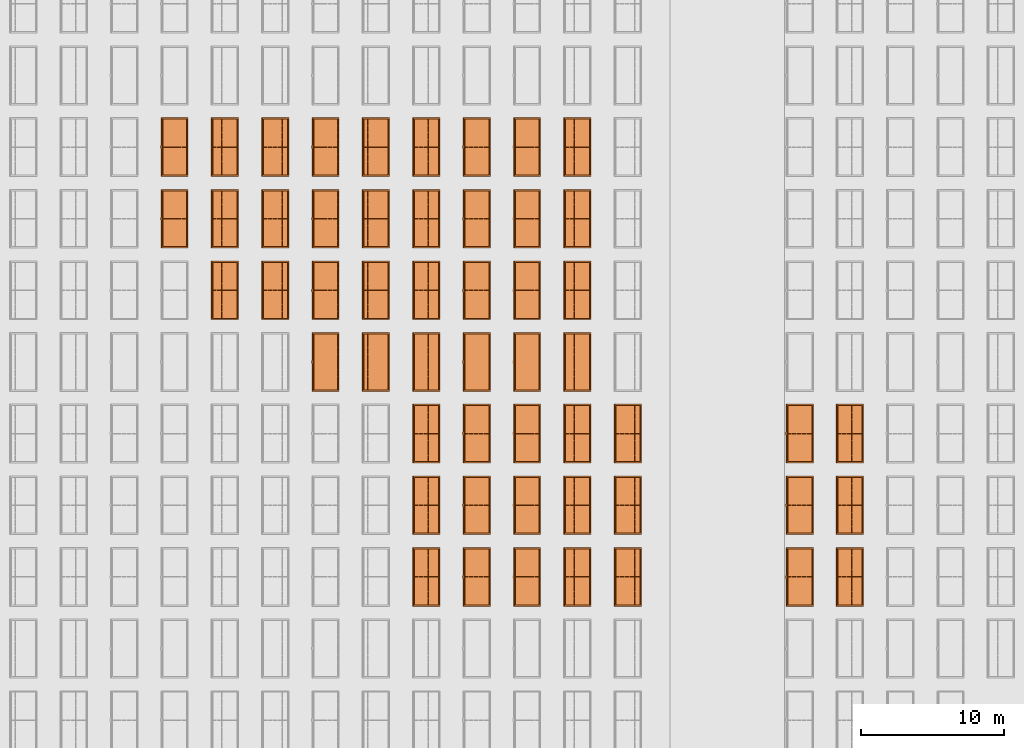
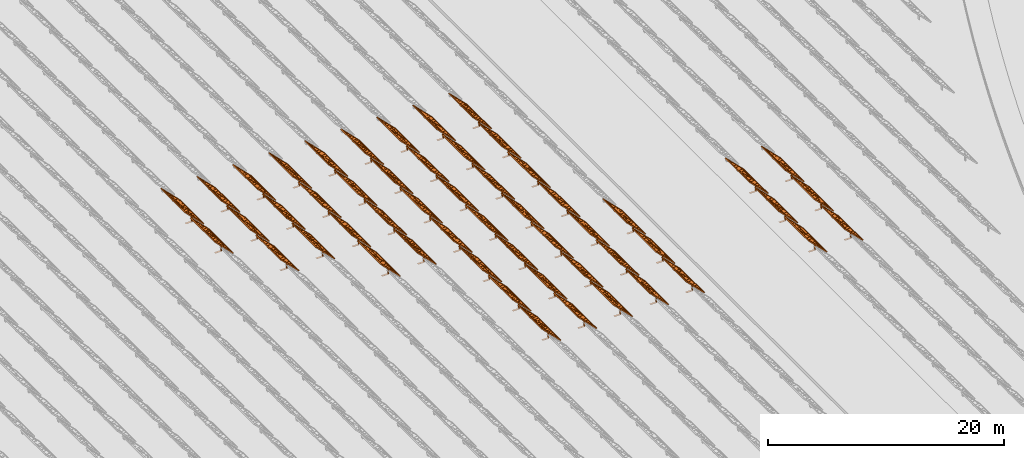
# One storey, part 25 of 39: 53 proxies.
"""IFC2X3 building model written with IfcOpenShell, lengths in millimetres."""

from ifc_helpers import new_model, entity, si_unit, converted_unit, derived_unit, direction, frame, frame_2d, origin, origin_2d_with_axis, place, context, subcontext, project, spatial, polyline, rectangle, outline, extrude, source, transform, mapped, material, material_list, element, save


model = new_model("IFC2X3")

# Units and contexts
model_context = context("Model", 3, precision=1e-06, world=origin(), true_north=direction((2.0, 6.12303176911189e-17, 1.0)))
context_of_model = context(None, 3, precision=1e-06, world=origin(), true_north=direction((2.0, 6.12303176911189e-17, 1.0)))
body_context = subcontext(model_context, "Body", "Model", "MODEL_VIEW")
ifc_project = project(units=[si_unit("LENGTHUNIT", "METRE", prefix="MILLI"), si_unit("AREAUNIT", "SQUARE_METRE", prefix="MILLI"), si_unit("VOLUMEUNIT", "CUBIC_METRE", prefix="MILLI"), converted_unit("PLANEANGLEUNIT", "DEGREE", entity("IfcRatioMeasure", 0.0174532925199433), si_unit("PLANEANGLEUNIT", "RADIAN"), dimensions=[0, 0, 0, 0, 0, 0, 0]), si_unit("MASSUNIT", "GRAM", prefix="KILO"), si_unit("TIMEUNIT", "SECOND"), si_unit("THERMODYNAMICTEMPERATUREUNIT", "KELVIN"), derived_unit("THERMALTRANSMITTANCEUNIT", [(si_unit("MASSUNIT", "GRAM", prefix="KILO"), 1), (si_unit("THERMODYNAMICTEMPERATUREUNIT", "KELVIN"), -1), (si_unit("TIMEUNIT", "SECOND"), -3)]), derived_unit("VOLUMETRICFLOWRATEUNIT", [(si_unit("LENGTHUNIT", "METRE"), 3), (si_unit("TIMEUNIT", "SECOND"), -1)])], contexts=[model_context, context_of_model])

# Site, building, storey
site_placement = place(None, origin())
site = spatial("IfcSite", under=ifc_project, at=site_placement, CompositionType="ELEMENT")
building_placement = place(site_placement, origin())
building = spatial("IfcBuilding", under=site, at=building_placement, CompositionType="ELEMENT")
storey_placement = place(building_placement, frame((0.0, 0.0, 4000.0)))
storey = spatial("IfcBuildingStorey", under=building, at=storey_placement, Name="Level 2", CompositionType="ELEMENT", Elevation=4000.0)

# Proxies
ifc_material_1 = material(Name="Stand-Steel")
ifc_material_2 = material(Name="Aluminium")
ifc_material_3 = material(Name="Glass")
ifc_material_list_1 = material_list([ifc_material_1, ifc_material_2, ifc_material_3])
shared_shape = source(origin(), body_context, "Body", "SweptSolid", [
    extrude(outline(polyline([(-629.526235435404, -220.0), (329.763117717702, -220.0), (329.763117717703, 410.0), (299.763117717703, 410.0), (299.763117717702, -190.0), (-629.526235435404, -190.0), (-629.526235435404, -220.0)])), frame((-190.00003127179, -100.0, 299.763117717707), z_axis=(0.0, 1.0, 0.0), x_axis=(0.0, 0.0, -1.0)), (0.0, 0.0, 1.0), 200.0),
    extrude(rectangle(XDim=20.0000000000001, YDim=200.0, at=frame_2d((0.0, -7.105427357601e-14), x_axis=(0.0, 1.0))), frame((-7.07109908365613, 0.0, 922.21828534124), z_axis=(-0.70710678118654, 0.0, 0.707106781186555), x_axis=(0.0, 1.0, 0.0)), (0.0, 0.0, 1.0), 2600.0),
    extrude(rectangle(XDim=24.9999999999997, YDim=24.9999999999999, at=frame_2d((2.87769807982841e-13, -9.50350909079134e-14), x_axis=(1.0, 0.0))), frame((-1449.56292018118, -1950.0, 2449.57494522722), z_axis=(0.0, 1.0, 0.0), x_axis=(-0.707106781186548, 0.0, -0.707106781186548)), (0.0, 0.0, 1.0), 3900.0),
    extrude(rectangle(XDim=24.9999999999999, YDim=25.0000000000001, at=origin_2d_with_axis()), frame((-1096.0095295879, -1950.0, 2096.02155463395), z_axis=(0.0, 1.0, 0.0), x_axis=(-0.707106781186542, 0.0, -0.707106781186553)), (0.0, 0.0, 1.0), 3900.0),
    extrude(rectangle(XDim=24.9999999999999, YDim=25.0000000000001, at=origin_2d_with_axis()), frame((-742.456138994631, -1950.0, 1742.46816404067), z_axis=(0.0, 1.0, 0.0), x_axis=(-0.707106781186542, 0.0, -0.707106781186553)), (0.0, 0.0, 1.0), 3900.0),
    extrude(rectangle(XDim=25.0, YDim=24.9999999999997, at=frame_2d((-7.19424519957101e-14, 1.19904086659517e-13), x_axis=(1.0, 0.0))), frame((-388.902748401358, -1950.0, 1388.9147734474), z_axis=(0.0, 1.0, 0.0), x_axis=(-0.707106781186545, 0.0, -0.70710678118655)), (0.0, 0.0, 1.0), 3900.0),
    extrude(rectangle(XDim=25.0000000000002, YDim=25.0, at=frame_2d((1.35891298214119e-13, 6.21724893790088e-15), x_axis=(0.0, 1.0))), frame((-35.3553703311048, 1500.0, 1035.35537033109), z_axis=(-0.707106781186544, 0.0, 0.707106781186551), x_axis=(0.0, 1.0, 0.0)), (0.0, 0.0, 1.0), 2440.0),
    extrude(rectangle(XDim=25.0000000000002, YDim=25.0, at=frame_2d((0.0, 1.77635683940025e-15), x_axis=(0.0, 1.0))), frame((-35.3553703311059, 1000.0, 1035.35537033109), z_axis=(-0.707106781186546, 0.0, 0.707106781186549), x_axis=(0.0, 1.0, 0.0)), (0.0, 0.0, 1.0), 2440.0),
    extrude(rectangle(XDim=25.0000000000002, YDim=25.0, at=frame_2d((0.0, 8.43769498715119e-14), x_axis=(0.0, 1.0))), frame((-26.5165355662756, 0.0, 1044.19420509593), z_axis=(-0.707106781186546, 0.0, 0.707106781186549), x_axis=(0.0, -1.0, 0.0)), (0.0, 0.0, 1.0), 2440.0),
    extrude(rectangle(XDim=25.0000000000002, YDim=25.0, at=frame_2d((0.0, 8.88178419700125e-16), x_axis=(0.0, 1.0))), frame((-35.3553703311065, 500.0, 1035.35537033109), z_axis=(-0.707106781186546, 0.0, 0.707106781186549), x_axis=(0.0, 1.0, 0.0)), (0.0, 0.0, 1.0), 2440.0),
    extrude(rectangle(XDim=25.0000000000002, YDim=25.0, at=frame_2d((0.0, 8.88178419700125e-16), x_axis=(0.0, 1.0))), frame((-35.3553703311086, -500.0, 1035.35537033109), z_axis=(-0.707106781186546, 0.0, 0.707106781186549), x_axis=(0.0, 1.0, 0.0)), (0.0, 0.0, 1.0), 2440.0),
    extrude(rectangle(XDim=25.0000000000002, YDim=25.0, at=frame_2d((0.0, 8.88178419700125e-16), x_axis=(0.0, 1.0))), frame((-35.3553703311095, -1000.0, 1035.35537033109), z_axis=(-0.707106781186546, 0.0, 0.707106781186549), x_axis=(0.0, 1.0, 0.0)), (0.0, 0.0, 1.0), 2440.0),
    extrude(rectangle(XDim=25.0000000000002, YDim=25.0, at=frame_2d((1.35891298214119e-13, 1.77635683940025e-15), x_axis=(0.0, 1.0))), frame((-35.3553703311107, -1500.0, 1035.35537033109), z_axis=(-0.707106781186546, 0.0, 0.707106781186549), x_axis=(0.0, 1.0, 0.0)), (0.0, 0.0, 1.0), 2440.0),
    extrude(rectangle(XDim=2400.0, YDim=11.9999999999994, at=frame_2d((-1.13686837721616e-13, 2.02948768901479e-13), x_axis=(1.0, 0.0))), frame((-883.883507754966, -1950.0, 1883.88350775495), z_axis=(0.0, 1.0, 0.0), x_axis=(0.707106781186546, 0.0, -0.707106781186549)), (0.0, 0.0, 1.0), 3900.0),
    extrude(outline(polyline([(-2050.0, -1300.0), (2050.0, -1300.0), (2050.0, 1300.0), (-2050.0, 1300.0), (-2050.0, -1300.0)]), holes=[polyline([(1950.0, -1200.0), (-1950.0, -1200.0), (-1950.0, 1200.0), (1950.0, 1200.0), (1950.0, -1200.0)])]), frame((-919.238846814293, 0.0, 1848.52816869563), z_axis=(0.707106781186554, 0.0, 0.707106781186541), x_axis=(0.0, 1.0, 0.0)), (0.0, 0.0, 1.0), 99.9999999999898),
])
proxy_1_placement = place(storey_placement, frame((-144385.32831183, 530144.680552408, 30.0)))
element("IfcBuildingElementProxy", 1, at=proxy_1_placement, inside=storey, material=ifc_material_list_1, Name="Solar Panel_4000X2500:Solar Panel_4000X2500", ObjectType="Solar Panel_4000X2500", CompositionType="ELEMENT", context=body_context, shape_type="MappedRepresentation", body=[
    mapped(shared_shape, transform((0.0, 0.0, 0.0), scale=1.0)),
])
ifc_material_list_2 = material_list([ifc_material_1, ifc_material_2, ifc_material_3])
proxy_2_placement = place(storey_placement, frame((-144385.32831183, 535144.680552408, 30.0)))
element("IfcBuildingElementProxy", 2, at=proxy_2_placement, inside=storey, material=ifc_material_list_2, Name="Solar Panel_4000X2500:Solar Panel_4000X2500", ObjectType="Solar Panel_4000X2500", CompositionType="ELEMENT", context=body_context, shape_type="MappedRepresentation", body=[
    mapped(shared_shape, transform((0.0, 0.0, 0.0), scale=1.0)),
])
ifc_material_list_3 = material_list([ifc_material_1, ifc_material_2, ifc_material_3])
proxy_3_placement = place(storey_placement, frame((-144385.32831183, 540144.680552408, 30.0)))
element("IfcBuildingElementProxy", 3, at=proxy_3_placement, inside=storey, material=ifc_material_list_3, Name="Solar Panel_4000X2500:Solar Panel_4000X2500", ObjectType="Solar Panel_4000X2500", CompositionType="ELEMENT", context=body_context, shape_type="MappedRepresentation", body=[
    mapped(shared_shape, transform((0.0, 0.0, 0.0), scale=1.0)),
])
ifc_material_list_4 = material_list([ifc_material_1, ifc_material_2, ifc_material_3])
proxy_4_placement = place(storey_placement, frame((-147885.32831183, 530144.680552408, 30.0)))
element("IfcBuildingElementProxy", 4, at=proxy_4_placement, inside=storey, material=ifc_material_list_4, Name="Solar Panel_4000X2500:Solar Panel_4000X2500", ObjectType="Solar Panel_4000X2500", CompositionType="ELEMENT", context=body_context, shape_type="MappedRepresentation", body=[
    mapped(shared_shape, transform((0.0, 0.0, 0.0), scale=1.0)),
])
ifc_material_list_5 = material_list([ifc_material_1, ifc_material_2, ifc_material_3])
proxy_5_placement = place(storey_placement, frame((-147885.32831183, 535144.680552408, 30.0)))
element("IfcBuildingElementProxy", 5, at=proxy_5_placement, inside=storey, material=ifc_material_list_5, Name="Solar Panel_4000X2500:Solar Panel_4000X2500", ObjectType="Solar Panel_4000X2500", CompositionType="ELEMENT", context=body_context, shape_type="MappedRepresentation", body=[
    mapped(shared_shape, transform((0.0, 0.0, 0.0), scale=1.0)),
])
ifc_material_list_6 = material_list([ifc_material_1, ifc_material_2, ifc_material_3])
proxy_6_placement = place(storey_placement, frame((-147885.32831183, 540144.680552408, 30.0)))
element("IfcBuildingElementProxy", 6, at=proxy_6_placement, inside=storey, material=ifc_material_list_6, Name="Solar Panel_4000X2500:Solar Panel_4000X2500", ObjectType="Solar Panel_4000X2500", CompositionType="ELEMENT", context=body_context, shape_type="MappedRepresentation", body=[
    mapped(shared_shape, transform((0.0, 0.0, 0.0), scale=1.0)),
])
ifc_material_list_7 = material_list([ifc_material_1, ifc_material_2, ifc_material_3])
proxy_7_placement = place(storey_placement, frame((-159885.32831183, 530144.680552408, 30.0)))
element("IfcBuildingElementProxy", 7, at=proxy_7_placement, inside=storey, material=ifc_material_list_7, Name="Solar Panel_4000X2500:Solar Panel_4000X2500", ObjectType="Solar Panel_4000X2500", CompositionType="ELEMENT", context=body_context, shape_type="MappedRepresentation", body=[
    mapped(shared_shape, transform((0.0, 0.0, 0.0), scale=1.0)),
])
ifc_material_list_8 = material_list([ifc_material_1, ifc_material_2, ifc_material_3])
proxy_8_placement = place(storey_placement, frame((-159885.32831183, 535144.680552408, 30.0)))
element("IfcBuildingElementProxy", 8, at=proxy_8_placement, inside=storey, material=ifc_material_list_8, Name="Solar Panel_4000X2500:Solar Panel_4000X2500", ObjectType="Solar Panel_4000X2500", CompositionType="ELEMENT", context=body_context, shape_type="MappedRepresentation", body=[
    mapped(shared_shape, transform((0.0, 0.0, 0.0), scale=1.0)),
])
ifc_material_list_9 = material_list([ifc_material_1, ifc_material_2, ifc_material_3])
proxy_9_placement = place(storey_placement, frame((-159885.32831183, 540144.680552408, 30.0)))
element("IfcBuildingElementProxy", 9, at=proxy_9_placement, inside=storey, material=ifc_material_list_9, Name="Solar Panel_4000X2500:Solar Panel_4000X2500", ObjectType="Solar Panel_4000X2500", CompositionType="ELEMENT", context=body_context, shape_type="MappedRepresentation", body=[
    mapped(shared_shape, transform((0.0, 0.0, 0.0), scale=1.0)),
])
ifc_material_list_10 = material_list([ifc_material_1, ifc_material_2, ifc_material_3])
proxy_10_placement = place(storey_placement, frame((-163400.32831183, 530144.680552408, 30.0)))
element("IfcBuildingElementProxy", 10, at=proxy_10_placement, inside=storey, material=ifc_material_list_10, Name="Solar Panel_4000X2500:Solar Panel_4000X2500", ObjectType="Solar Panel_4000X2500", CompositionType="ELEMENT", context=body_context, shape_type="MappedRepresentation", body=[
    mapped(shared_shape, transform((0.0, 0.0, 0.0), scale=1.0)),
])
ifc_material_list_11 = material_list([ifc_material_1, ifc_material_2, ifc_material_3])
proxy_11_placement = place(storey_placement, frame((-163400.32831183, 535144.680552408, 30.0)))
element("IfcBuildingElementProxy", 11, at=proxy_11_placement, inside=storey, material=ifc_material_list_11, Name="Solar Panel_4000X2500:Solar Panel_4000X2500", ObjectType="Solar Panel_4000X2500", CompositionType="ELEMENT", context=body_context, shape_type="MappedRepresentation", body=[
    mapped(shared_shape, transform((0.0, 0.0, 0.0), scale=1.0)),
])
ifc_material_list_12 = material_list([ifc_material_1, ifc_material_2, ifc_material_3])
proxy_12_placement = place(storey_placement, frame((-163400.32831183, 540144.680552408, 30.0)))
element("IfcBuildingElementProxy", 12, at=proxy_12_placement, inside=storey, material=ifc_material_list_12, Name="Solar Panel_4000X2500:Solar Panel_4000X2500", ObjectType="Solar Panel_4000X2500", CompositionType="ELEMENT", context=body_context, shape_type="MappedRepresentation", body=[
    mapped(shared_shape, transform((0.0, 0.0, 0.0), scale=1.0)),
])
ifc_material_list_13 = material_list([ifc_material_1, ifc_material_2, ifc_material_3])
proxy_13_placement = place(storey_placement, frame((-163400.32831183, 545144.680552408, 30.0)))
element("IfcBuildingElementProxy", 13, at=proxy_13_placement, inside=storey, material=ifc_material_list_13, Name="Solar Panel_4000X2500:Solar Panel_4000X2500", ObjectType="Solar Panel_4000X2500", CompositionType="ELEMENT", context=body_context, shape_type="MappedRepresentation", body=[
    mapped(shared_shape, transform((0.0, 0.0, 0.0), scale=1.0)),
])
ifc_material_list_14 = material_list([ifc_material_1, ifc_material_2, ifc_material_3])
proxy_14_placement = place(storey_placement, frame((-163400.32831183, 550144.680552408, 30.0)))
element("IfcBuildingElementProxy", 14, at=proxy_14_placement, inside=storey, material=ifc_material_list_14, Name="Solar Panel_4000X2500:Solar Panel_4000X2500", ObjectType="Solar Panel_4000X2500", CompositionType="ELEMENT", context=body_context, shape_type="MappedRepresentation", body=[
    mapped(shared_shape, transform((0.0, 0.0, 0.0), scale=1.0)),
])
ifc_material_list_15 = material_list([ifc_material_1, ifc_material_2, ifc_material_3])
proxy_15_placement = place(storey_placement, frame((-163400.32831183, 555144.680552408, 30.0)))
element("IfcBuildingElementProxy", 15, at=proxy_15_placement, inside=storey, material=ifc_material_list_15, Name="Solar Panel_4000X2500:Solar Panel_4000X2500", ObjectType="Solar Panel_4000X2500", CompositionType="ELEMENT", context=body_context, shape_type="MappedRepresentation", body=[
    mapped(shared_shape, transform((0.0, 0.0, 0.0), scale=1.0)),
])
ifc_material_list_16 = material_list([ifc_material_1, ifc_material_2, ifc_material_3])
proxy_16_placement = place(storey_placement, frame((-163400.32831183, 560144.680552408, 30.0)))
element("IfcBuildingElementProxy", 16, at=proxy_16_placement, inside=storey, material=ifc_material_list_16, Name="Solar Panel_4000X2500:Solar Panel_4000X2500", ObjectType="Solar Panel_4000X2500", CompositionType="ELEMENT", context=body_context, shape_type="MappedRepresentation", body=[
    mapped(shared_shape, transform((0.0, 0.0, 0.0), scale=1.0)),
])
ifc_material_list_17 = material_list([ifc_material_1, ifc_material_2, ifc_material_3])
proxy_17_placement = place(storey_placement, frame((-166915.32831183, 530144.680552408, 30.0)))
element("IfcBuildingElementProxy", 17, at=proxy_17_placement, inside=storey, material=ifc_material_list_17, Name="Solar Panel_4000X2500:Solar Panel_4000X2500", ObjectType="Solar Panel_4000X2500", CompositionType="ELEMENT", context=body_context, shape_type="MappedRepresentation", body=[
    mapped(shared_shape, transform((0.0, 0.0, 0.0), scale=1.0)),
])
ifc_material_list_18 = material_list([ifc_material_1, ifc_material_2, ifc_material_3])
proxy_18_placement = place(storey_placement, frame((-166915.32831183, 535144.680552408, 30.0)))
element("IfcBuildingElementProxy", 18, at=proxy_18_placement, inside=storey, material=ifc_material_list_18, Name="Solar Panel_4000X2500:Solar Panel_4000X2500", ObjectType="Solar Panel_4000X2500", CompositionType="ELEMENT", context=body_context, shape_type="MappedRepresentation", body=[
    mapped(shared_shape, transform((0.0, 0.0, 0.0), scale=1.0)),
])
ifc_material_list_19 = material_list([ifc_material_1, ifc_material_2, ifc_material_3])
proxy_19_placement = place(storey_placement, frame((-166915.32831183, 540144.680552408, 30.0)))
element("IfcBuildingElementProxy", 19, at=proxy_19_placement, inside=storey, material=ifc_material_list_19, Name="Solar Panel_4000X2500:Solar Panel_4000X2500", ObjectType="Solar Panel_4000X2500", CompositionType="ELEMENT", context=body_context, shape_type="MappedRepresentation", body=[
    mapped(shared_shape, transform((0.0, 0.0, 0.0), scale=1.0)),
])
ifc_material_list_20 = material_list([ifc_material_1, ifc_material_2, ifc_material_3])
proxy_20_placement = place(storey_placement, frame((-166915.32831183, 545144.680552408, 30.0)))
element("IfcBuildingElementProxy", 20, at=proxy_20_placement, inside=storey, material=ifc_material_list_20, Name="Solar Panel_4000X2500:Solar Panel_4000X2500", ObjectType="Solar Panel_4000X2500", CompositionType="ELEMENT", context=body_context, shape_type="MappedRepresentation", body=[
    mapped(shared_shape, transform((0.0, 0.0, 0.0), scale=1.0)),
])
ifc_material_list_21 = material_list([ifc_material_1, ifc_material_2, ifc_material_3])
proxy_21_placement = place(storey_placement, frame((-166915.32831183, 550144.680552408, 30.0)))
element("IfcBuildingElementProxy", 21, at=proxy_21_placement, inside=storey, material=ifc_material_list_21, Name="Solar Panel_4000X2500:Solar Panel_4000X2500", ObjectType="Solar Panel_4000X2500", CompositionType="ELEMENT", context=body_context, shape_type="MappedRepresentation", body=[
    mapped(shared_shape, transform((0.0, 0.0, 0.0), scale=1.0)),
])
ifc_material_list_22 = material_list([ifc_material_1, ifc_material_2, ifc_material_3])
proxy_22_placement = place(storey_placement, frame((-166915.32831183, 555144.680552408, 30.0)))
element("IfcBuildingElementProxy", 22, at=proxy_22_placement, inside=storey, material=ifc_material_list_22, Name="Solar Panel_4000X2500:Solar Panel_4000X2500", ObjectType="Solar Panel_4000X2500", CompositionType="ELEMENT", context=body_context, shape_type="MappedRepresentation", body=[
    mapped(shared_shape, transform((0.0, 0.0, 0.0), scale=1.0)),
])
ifc_material_list_23 = material_list([ifc_material_1, ifc_material_2, ifc_material_3])
proxy_23_placement = place(storey_placement, frame((-166915.32831183, 560144.680552408, 30.0)))
element("IfcBuildingElementProxy", 23, at=proxy_23_placement, inside=storey, material=ifc_material_list_23, Name="Solar Panel_4000X2500:Solar Panel_4000X2500", ObjectType="Solar Panel_4000X2500", CompositionType="ELEMENT", context=body_context, shape_type="MappedRepresentation", body=[
    mapped(shared_shape, transform((0.0, 0.0, 0.0), scale=1.0)),
])
ifc_material_list_24 = material_list([ifc_material_1, ifc_material_2, ifc_material_3])
proxy_24_placement = place(storey_placement, frame((-170430.32831183, 530144.680552408, 30.0)))
element("IfcBuildingElementProxy", 24, at=proxy_24_placement, inside=storey, material=ifc_material_list_24, Name="Solar Panel_4000X2500:Solar Panel_4000X2500", ObjectType="Solar Panel_4000X2500", CompositionType="ELEMENT", context=body_context, shape_type="MappedRepresentation", body=[
    mapped(shared_shape, transform((0.0, 0.0, 0.0), scale=1.0)),
])
ifc_material_list_25 = material_list([ifc_material_1, ifc_material_2, ifc_material_3])
proxy_25_placement = place(storey_placement, frame((-170430.32831183, 535144.680552408, 30.0)))
element("IfcBuildingElementProxy", 25, at=proxy_25_placement, inside=storey, material=ifc_material_list_25, Name="Solar Panel_4000X2500:Solar Panel_4000X2500", ObjectType="Solar Panel_4000X2500", CompositionType="ELEMENT", context=body_context, shape_type="MappedRepresentation", body=[
    mapped(shared_shape, transform((0.0, 0.0, 0.0), scale=1.0)),
])
ifc_material_list_26 = material_list([ifc_material_1, ifc_material_2, ifc_material_3])
proxy_26_placement = place(storey_placement, frame((-170430.32831183, 540144.680552408, 30.0)))
element("IfcBuildingElementProxy", 26, at=proxy_26_placement, inside=storey, material=ifc_material_list_26, Name="Solar Panel_4000X2500:Solar Panel_4000X2500", ObjectType="Solar Panel_4000X2500", CompositionType="ELEMENT", context=body_context, shape_type="MappedRepresentation", body=[
    mapped(shared_shape, transform((0.0, 0.0, 0.0), scale=1.0)),
])
ifc_material_list_27 = material_list([ifc_material_1, ifc_material_2, ifc_material_3])
proxy_27_placement = place(storey_placement, frame((-170430.32831183, 545144.680552408, 30.0)))
element("IfcBuildingElementProxy", 27, at=proxy_27_placement, inside=storey, material=ifc_material_list_27, Name="Solar Panel_4000X2500:Solar Panel_4000X2500", ObjectType="Solar Panel_4000X2500", CompositionType="ELEMENT", context=body_context, shape_type="MappedRepresentation", body=[
    mapped(shared_shape, transform((0.0, 0.0, 0.0), scale=1.0)),
])
ifc_material_list_28 = material_list([ifc_material_1, ifc_material_2, ifc_material_3])
proxy_28_placement = place(storey_placement, frame((-170430.32831183, 550144.680552408, 30.0)))
element("IfcBuildingElementProxy", 28, at=proxy_28_placement, inside=storey, material=ifc_material_list_28, Name="Solar Panel_4000X2500:Solar Panel_4000X2500", ObjectType="Solar Panel_4000X2500", CompositionType="ELEMENT", context=body_context, shape_type="MappedRepresentation", body=[
    mapped(shared_shape, transform((0.0, 0.0, 0.0), scale=1.0)),
])
ifc_material_list_29 = material_list([ifc_material_1, ifc_material_2, ifc_material_3])
proxy_29_placement = place(storey_placement, frame((-170430.32831183, 555144.680552408, 30.0)))
element("IfcBuildingElementProxy", 29, at=proxy_29_placement, inside=storey, material=ifc_material_list_29, Name="Solar Panel_4000X2500:Solar Panel_4000X2500", ObjectType="Solar Panel_4000X2500", CompositionType="ELEMENT", context=body_context, shape_type="MappedRepresentation", body=[
    mapped(shared_shape, transform((0.0, 0.0, 0.0), scale=1.0)),
])
ifc_material_list_30 = material_list([ifc_material_1, ifc_material_2, ifc_material_3])
proxy_30_placement = place(storey_placement, frame((-170430.32831183, 560144.680552408, 30.0)))
element("IfcBuildingElementProxy", 30, at=proxy_30_placement, inside=storey, material=ifc_material_list_30, Name="Solar Panel_4000X2500:Solar Panel_4000X2500", ObjectType="Solar Panel_4000X2500", CompositionType="ELEMENT", context=body_context, shape_type="MappedRepresentation", body=[
    mapped(shared_shape, transform((0.0, 0.0, 0.0), scale=1.0)),
])
ifc_material_list_31 = material_list([ifc_material_1, ifc_material_2, ifc_material_3])
proxy_31_placement = place(storey_placement, frame((-173945.32831183, 530144.680552408, 30.0)))
element("IfcBuildingElementProxy", 31, at=proxy_31_placement, inside=storey, material=ifc_material_list_31, Name="Solar Panel_4000X2500:Solar Panel_4000X2500", ObjectType="Solar Panel_4000X2500", CompositionType="ELEMENT", context=body_context, shape_type="MappedRepresentation", body=[
    mapped(shared_shape, transform((0.0, 0.0, 0.0), scale=1.0)),
])
ifc_material_list_32 = material_list([ifc_material_1, ifc_material_2, ifc_material_3])
proxy_32_placement = place(storey_placement, frame((-173945.32831183, 535144.680552408, 30.0)))
element("IfcBuildingElementProxy", 32, at=proxy_32_placement, inside=storey, material=ifc_material_list_32, Name="Solar Panel_4000X2500:Solar Panel_4000X2500", ObjectType="Solar Panel_4000X2500", CompositionType="ELEMENT", context=body_context, shape_type="MappedRepresentation", body=[
    mapped(shared_shape, transform((0.0, 0.0, 0.0), scale=1.0)),
])
ifc_material_list_33 = material_list([ifc_material_1, ifc_material_2, ifc_material_3])
proxy_33_placement = place(storey_placement, frame((-173945.32831183, 540144.680552408, 30.0)))
element("IfcBuildingElementProxy", 33, at=proxy_33_placement, inside=storey, material=ifc_material_list_33, Name="Solar Panel_4000X2500:Solar Panel_4000X2500", ObjectType="Solar Panel_4000X2500", CompositionType="ELEMENT", context=body_context, shape_type="MappedRepresentation", body=[
    mapped(shared_shape, transform((0.0, 0.0, 0.0), scale=1.0)),
])
ifc_material_list_34 = material_list([ifc_material_1, ifc_material_2, ifc_material_3])
proxy_34_placement = place(storey_placement, frame((-173945.32831183, 545144.680552408, 30.0)))
element("IfcBuildingElementProxy", 34, at=proxy_34_placement, inside=storey, material=ifc_material_list_34, Name="Solar Panel_4000X2500:Solar Panel_4000X2500", ObjectType="Solar Panel_4000X2500", CompositionType="ELEMENT", context=body_context, shape_type="MappedRepresentation", body=[
    mapped(shared_shape, transform((0.0, 0.0, 0.0), scale=1.0)),
])
ifc_material_list_35 = material_list([ifc_material_1, ifc_material_2, ifc_material_3])
proxy_35_placement = place(storey_placement, frame((-173945.32831183, 550144.680552408, 30.0)))
element("IfcBuildingElementProxy", 35, at=proxy_35_placement, inside=storey, material=ifc_material_list_35, Name="Solar Panel_4000X2500:Solar Panel_4000X2500", ObjectType="Solar Panel_4000X2500", CompositionType="ELEMENT", context=body_context, shape_type="MappedRepresentation", body=[
    mapped(shared_shape, transform((0.0, 0.0, 0.0), scale=1.0)),
])
ifc_material_list_36 = material_list([ifc_material_1, ifc_material_2, ifc_material_3])
proxy_36_placement = place(storey_placement, frame((-173945.32831183, 555144.680552408, 30.0)))
element("IfcBuildingElementProxy", 36, at=proxy_36_placement, inside=storey, material=ifc_material_list_36, Name="Solar Panel_4000X2500:Solar Panel_4000X2500", ObjectType="Solar Panel_4000X2500", CompositionType="ELEMENT", context=body_context, shape_type="MappedRepresentation", body=[
    mapped(shared_shape, transform((0.0, 0.0, 0.0), scale=1.0)),
])
ifc_material_list_37 = material_list([ifc_material_1, ifc_material_2, ifc_material_3])
proxy_37_placement = place(storey_placement, frame((-173945.32831183, 560144.680552408, 30.0)))
element("IfcBuildingElementProxy", 37, at=proxy_37_placement, inside=storey, material=ifc_material_list_37, Name="Solar Panel_4000X2500:Solar Panel_4000X2500", ObjectType="Solar Panel_4000X2500", CompositionType="ELEMENT", context=body_context, shape_type="MappedRepresentation", body=[
    mapped(shared_shape, transform((0.0, 0.0, 0.0), scale=1.0)),
])
ifc_material_list_38 = material_list([ifc_material_1, ifc_material_2, ifc_material_3])
proxy_38_placement = place(storey_placement, frame((-177460.32831183, 545144.680552408, 30.0)))
element("IfcBuildingElementProxy", 38, at=proxy_38_placement, inside=storey, material=ifc_material_list_38, Name="Solar Panel_4000X2500:Solar Panel_4000X2500", ObjectType="Solar Panel_4000X2500", CompositionType="ELEMENT", context=body_context, shape_type="MappedRepresentation", body=[
    mapped(shared_shape, transform((0.0, 0.0, 0.0), scale=1.0)),
])
ifc_material_list_39 = material_list([ifc_material_1, ifc_material_2, ifc_material_3])
proxy_39_placement = place(storey_placement, frame((-177460.32831183, 550144.680552408, 30.0)))
element("IfcBuildingElementProxy", 39, at=proxy_39_placement, inside=storey, material=ifc_material_list_39, Name="Solar Panel_4000X2500:Solar Panel_4000X2500", ObjectType="Solar Panel_4000X2500", CompositionType="ELEMENT", context=body_context, shape_type="MappedRepresentation", body=[
    mapped(shared_shape, transform((0.0, 0.0, 0.0), scale=1.0)),
])
ifc_material_list_40 = material_list([ifc_material_1, ifc_material_2, ifc_material_3])
proxy_40_placement = place(storey_placement, frame((-177460.32831183, 555144.680552408, 30.0)))
element("IfcBuildingElementProxy", 40, at=proxy_40_placement, inside=storey, material=ifc_material_list_40, Name="Solar Panel_4000X2500:Solar Panel_4000X2500", ObjectType="Solar Panel_4000X2500", CompositionType="ELEMENT", context=body_context, shape_type="MappedRepresentation", body=[
    mapped(shared_shape, transform((0.0, 0.0, 0.0), scale=1.0)),
])
ifc_material_list_41 = material_list([ifc_material_1, ifc_material_2, ifc_material_3])
proxy_41_placement = place(storey_placement, frame((-177460.32831183, 560144.680552408, 30.0)))
element("IfcBuildingElementProxy", 41, at=proxy_41_placement, inside=storey, material=ifc_material_list_41, Name="Solar Panel_4000X2500:Solar Panel_4000X2500", ObjectType="Solar Panel_4000X2500", CompositionType="ELEMENT", context=body_context, shape_type="MappedRepresentation", body=[
    mapped(shared_shape, transform((0.0, 0.0, 0.0), scale=1.0)),
])
ifc_material_list_42 = material_list([ifc_material_1, ifc_material_2, ifc_material_3])
proxy_42_placement = place(storey_placement, frame((-180975.32831183, 545144.680552408, 30.0)))
element("IfcBuildingElementProxy", 42, at=proxy_42_placement, inside=storey, material=ifc_material_list_42, Name="Solar Panel_4000X2500:Solar Panel_4000X2500", ObjectType="Solar Panel_4000X2500", CompositionType="ELEMENT", context=body_context, shape_type="MappedRepresentation", body=[
    mapped(shared_shape, transform((0.0, 0.0, 0.0), scale=1.0)),
])
ifc_material_list_43 = material_list([ifc_material_1, ifc_material_2, ifc_material_3])
proxy_43_placement = place(storey_placement, frame((-180975.32831183, 550144.680552408, 30.0)))
element("IfcBuildingElementProxy", 43, at=proxy_43_placement, inside=storey, material=ifc_material_list_43, Name="Solar Panel_4000X2500:Solar Panel_4000X2500", ObjectType="Solar Panel_4000X2500", CompositionType="ELEMENT", context=body_context, shape_type="MappedRepresentation", body=[
    mapped(shared_shape, transform((0.0, 0.0, 0.0), scale=1.0)),
])
ifc_material_list_44 = material_list([ifc_material_1, ifc_material_2, ifc_material_3])
proxy_44_placement = place(storey_placement, frame((-180975.32831183, 555144.680552408, 30.0)))
element("IfcBuildingElementProxy", 44, at=proxy_44_placement, inside=storey, material=ifc_material_list_44, Name="Solar Panel_4000X2500:Solar Panel_4000X2500", ObjectType="Solar Panel_4000X2500", CompositionType="ELEMENT", context=body_context, shape_type="MappedRepresentation", body=[
    mapped(shared_shape, transform((0.0, 0.0, 0.0), scale=1.0)),
])
ifc_material_list_45 = material_list([ifc_material_1, ifc_material_2, ifc_material_3])
proxy_45_placement = place(storey_placement, frame((-180975.32831183, 560144.680552408, 30.0)))
element("IfcBuildingElementProxy", 45, at=proxy_45_placement, inside=storey, material=ifc_material_list_45, Name="Solar Panel_4000X2500:Solar Panel_4000X2500", ObjectType="Solar Panel_4000X2500", CompositionType="ELEMENT", context=body_context, shape_type="MappedRepresentation", body=[
    mapped(shared_shape, transform((0.0, 0.0, 0.0), scale=1.0)),
])
ifc_material_list_46 = material_list([ifc_material_1, ifc_material_2, ifc_material_3])
proxy_46_placement = place(storey_placement, frame((-184490.32831183, 550144.680552408, 30.0)))
element("IfcBuildingElementProxy", 46, at=proxy_46_placement, inside=storey, material=ifc_material_list_46, Name="Solar Panel_4000X2500:Solar Panel_4000X2500", ObjectType="Solar Panel_4000X2500", CompositionType="ELEMENT", context=body_context, shape_type="MappedRepresentation", body=[
    mapped(shared_shape, transform((0.0, 0.0, 0.0), scale=1.0)),
])
ifc_material_list_47 = material_list([ifc_material_1, ifc_material_2, ifc_material_3])
proxy_47_placement = place(storey_placement, frame((-184490.32831183, 555144.680552408, 30.0)))
element("IfcBuildingElementProxy", 47, at=proxy_47_placement, inside=storey, material=ifc_material_list_47, Name="Solar Panel_4000X2500:Solar Panel_4000X2500", ObjectType="Solar Panel_4000X2500", CompositionType="ELEMENT", context=body_context, shape_type="MappedRepresentation", body=[
    mapped(shared_shape, transform((0.0, 0.0, 0.0), scale=1.0)),
])
ifc_material_list_48 = material_list([ifc_material_1, ifc_material_2, ifc_material_3])
proxy_48_placement = place(storey_placement, frame((-184490.32831183, 560144.680552408, 30.0)))
element("IfcBuildingElementProxy", 48, at=proxy_48_placement, inside=storey, material=ifc_material_list_48, Name="Solar Panel_4000X2500:Solar Panel_4000X2500", ObjectType="Solar Panel_4000X2500", CompositionType="ELEMENT", context=body_context, shape_type="MappedRepresentation", body=[
    mapped(shared_shape, transform((0.0, 0.0, 0.0), scale=1.0)),
])
ifc_material_list_49 = material_list([ifc_material_1, ifc_material_2, ifc_material_3])
proxy_49_placement = place(storey_placement, frame((-188005.32831183, 550144.680552408, 30.0)))
element("IfcBuildingElementProxy", 49, at=proxy_49_placement, inside=storey, material=ifc_material_list_49, Name="Solar Panel_4000X2500:Solar Panel_4000X2500", ObjectType="Solar Panel_4000X2500", CompositionType="ELEMENT", context=body_context, shape_type="MappedRepresentation", body=[
    mapped(shared_shape, transform((0.0, 0.0, 0.0), scale=1.0)),
])
ifc_material_list_50 = material_list([ifc_material_1, ifc_material_2, ifc_material_3])
proxy_50_placement = place(storey_placement, frame((-188005.32831183, 555144.680552408, 30.0)))
element("IfcBuildingElementProxy", 50, at=proxy_50_placement, inside=storey, material=ifc_material_list_50, Name="Solar Panel_4000X2500:Solar Panel_4000X2500", ObjectType="Solar Panel_4000X2500", CompositionType="ELEMENT", context=body_context, shape_type="MappedRepresentation", body=[
    mapped(shared_shape, transform((0.0, 0.0, 0.0), scale=1.0)),
])
ifc_material_list_51 = material_list([ifc_material_1, ifc_material_2, ifc_material_3])
proxy_51_placement = place(storey_placement, frame((-188005.32831183, 560144.680552408, 30.0)))
element("IfcBuildingElementProxy", 51, at=proxy_51_placement, inside=storey, material=ifc_material_list_51, Name="Solar Panel_4000X2500:Solar Panel_4000X2500", ObjectType="Solar Panel_4000X2500", CompositionType="ELEMENT", context=body_context, shape_type="MappedRepresentation", body=[
    mapped(shared_shape, transform((0.0, 0.0, 0.0), scale=1.0)),
])
ifc_material_list_52 = material_list([ifc_material_1, ifc_material_2, ifc_material_3])
proxy_52_placement = place(storey_placement, frame((-191520.32831183, 555144.680552408, 30.0)))
element("IfcBuildingElementProxy", 52, at=proxy_52_placement, inside=storey, material=ifc_material_list_52, Name="Solar Panel_4000X2500:Solar Panel_4000X2500", ObjectType="Solar Panel_4000X2500", CompositionType="ELEMENT", context=body_context, shape_type="MappedRepresentation", body=[
    mapped(shared_shape, transform((0.0, 0.0, 0.0), scale=1.0)),
])
ifc_material_list_53 = material_list([ifc_material_1, ifc_material_2, ifc_material_3])
proxy_53_placement = place(storey_placement, frame((-191520.32831183, 560144.680552408, 30.0)))
element("IfcBuildingElementProxy", 53, at=proxy_53_placement, inside=storey, material=ifc_material_list_53, Name="Solar Panel_4000X2500:Solar Panel_4000X2500", ObjectType="Solar Panel_4000X2500", CompositionType="ELEMENT", context=body_context, shape_type="MappedRepresentation", body=[
    mapped(shared_shape, transform((0.0, 0.0, 0.0), scale=1.0)),
])

save(model, "model.ifc")
